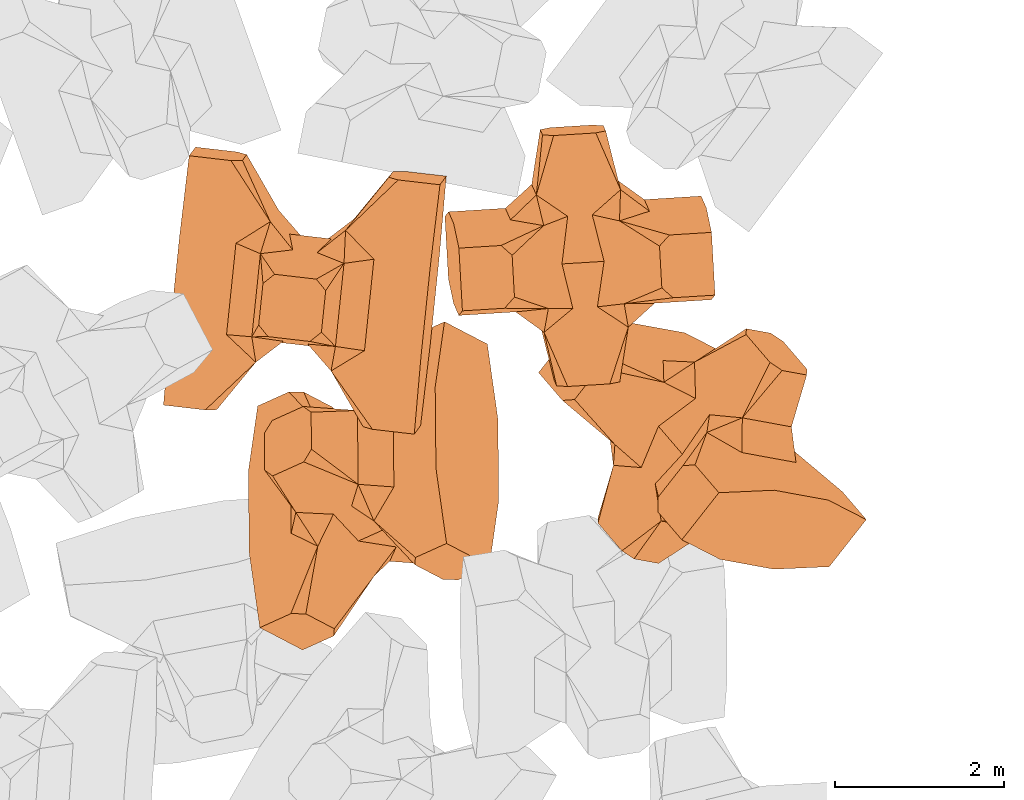
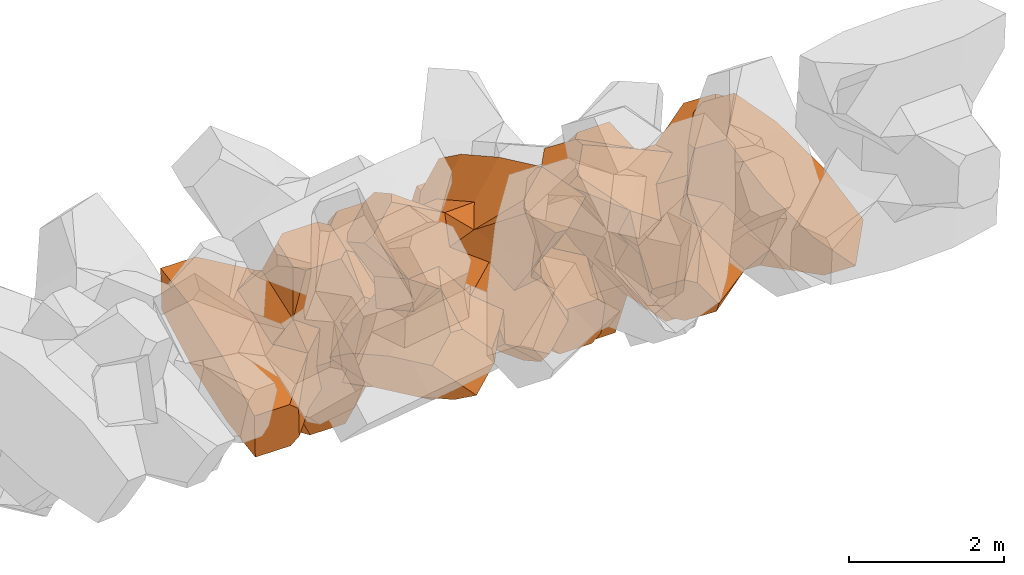
# One storey, part 16 of 17: 4 civil elements.
"""IFC4 building model written with IfcOpenShell, lengths in metres."""

from ifc_helpers import new_model, entity, si_unit, converted_unit, frame, origin_with_axes, origin_2d_with_axis, place, context, subcontext, project, spatial, polygons, element, save


model = new_model("IFC4")

# Units and contexts
model_context = context("Model", 3, precision=1e-05, world=origin_with_axes())
plan_context = context("Plan", 2, precision=1e-05, world=origin_2d_with_axis())
body_context = subcontext(model_context, "Body", "Model", "MODEL_VIEW")
ifc_project = project(units=[si_unit("VOLUMEUNIT", "CUBIC_METRE"), si_unit("LENGTHUNIT", "METRE"), converted_unit("PLANEANGLEUNIT", "degree", entity("IfcReal", 0.0174532925199433), si_unit("PLANEANGLEUNIT", "RADIAN"), dimensions=[0, 0, 0, 0, 0, 0, 0]), si_unit("AREAUNIT", "SQUARE_METRE")], contexts=[model_context, plan_context])

# Site, building, storey
site_placement = place(None, origin_with_axes())
site = spatial("IfcSite", under=ifc_project, at=site_placement)
building_placement = place(site_placement, origin_with_axes())
building = spatial("IfcBuilding", under=site, at=building_placement, Name="Building")
storey_placement = place(building_placement, origin_with_axes())
storey = spatial("IfcBuildingStorey", under=building, at=storey_placement, Name="Storey")

# Civil elements
civil_element_1_placement = place(storey_placement, frame((17.6803112030029, 17.7688827514648, 3.55769681930542), z_axis=(0.100111402480359, 0.136182114358353, -0.985612570345115), x_axis=(0.10141891959531, 0.984032866758023, 0.146265238139852)))
element("IfcCivilElement", 1, at=civil_element_1_placement, inside=storey, ObjectType="IfcCivilElementType", context=body_context, shape_type="Tessellation", body=[
    polygons([(0.500000178813934, 0.500002086162567, 0.821431398391724), (0.374999850988388, 0.250000953674316, 1.50000500679016), (0.550000071525574, 0.145681202411652, 0.550001919269562), (0.374999850988388, -0.250001013278961, 1.50000500679016), (0.651315867900848, -0.250001013278961, 1.45971029041903e-07), (0.651315867900848, 0.250000953674316, 1.45971029041903e-07), (0.550000071525574, -0.145681276917458, 0.550001919269562), (0.500000178813934, -0.500002086162567, 0.821431398391724), (-0.250000029802322, 0.375001281499863, 1.50000500679016), (0.249999985098839, 0.375001281499863, 1.50000500679016), (-0.500000059604645, 0.500002086162567, 0.821431398391724), (-0.550000071525574, 0.825003266334534, 0.550001919269562), (0.550000071525574, 0.825003266334534, 0.550001919269562), (-0.550000071525574, 1.50000607967377, 0.550001919269562), (0.550000071525574, 1.50000607967377, 0.550001919269562), (-0.250000029802322, -0.375001519918442, 1.50000500679016), (0.249999985098839, -0.375001519918442, 1.50000500679016), (-0.375, -0.250001013278961, 1.50000500679016), (-0.375, 0.250000953674316, 1.50000500679016), (1.50000023841858, 0.875003337860107, -0.25000062584877), (1.50000023841858, 0.875003337860107, 0.250000923871994), (0.845557630062103, 0.450001686811447, -0.495556741952896), (0.845557630062103, 0.450001686811447, 0.495556741952896), (1.50000023841858, 1.50000607967377, -0.375001043081284), (1.50000023841858, 1.50000607967377, 0.375001192092896), (1.50000023841858, 1.00000405311584, -0.375001043081284), (1.50000023841858, 1.00000405311584, 0.375001192092896), (-1.50000023841858, 1.50000607967377, -0.375001043081284), (-1.50000023841858, 1.50000607967377, 0.375001192092896), (-0.550000071525574, 1.50000607967377, -0.550001621246338), (0.550000071525574, 1.50000607967377, -0.550001621246338), (0.550000071525574, 0.145681202411652, -0.550001621246338), (-0.500000059604645, -0.500002086162567, 0.821431398391724), (-0.550000071525574, -0.145681276917458, 0.550001919269562), (-0.651315867900848, 0.250000953674316, 1.45971029041903e-07), (-0.651315867900848, -0.250001013278961, 1.45971029041903e-07), (-0.550000071525574, 0.145681202411652, 0.550001919269562), (-1.50000023841858, 0.875003337860107, 0.250000923871994), (-1.50000023841858, 0.875003337860107, -0.25000062584877), (-0.845557451248169, 0.450001686811447, 0.495556741952896), (-0.845557451248169, 0.450001686811447, -0.495556741952896), (-1.50000023841858, 1.00000405311584, 0.375001192092896), (-1.50000023841858, 1.00000405311584, -0.375001043081284), (-0.550000071525574, 0.145681202411652, -0.550001621246338), (0.550000071525574, -0.825003445148468, 0.550001919269562), (-0.550000071525574, -0.825003445148468, 0.550001919269562), (0.550000071525574, -1.50000607967377, 0.550001919269562), (-0.550000071525574, -1.50000607967377, 0.550001919269562), (1.50000023841858, -0.875003576278687, 0.250000923871994), (1.50000023841858, -0.875003576278687, -0.25000062584877), (0.845557630062103, -0.450001925230026, 0.495556741952896), (0.845557630062103, -0.450001925230026, -0.495556741952896), (1.50000023841858, -1.50000607967377, 0.375001192092896), (1.50000023841858, -1.50000607967377, -0.375001043081284), (1.50000023841858, -1.00000417232513, 0.375001192092896), (1.50000023841858, -1.00000417232513, -0.375001043081284), (0.550000071525574, -1.50000607967377, -0.550001621246338), (-0.550000071525574, -1.50000607967377, -0.550001621246338), (-1.50000023841858, -1.50000607967377, -0.375001043081284), (-1.50000023841858, -1.50000607967377, 0.375001192092896), (0.550000071525574, -0.145681276917458, -0.550001621246338), (-1.50000023841858, -0.875003576278687, -0.25000062584877), (-1.50000023841858, -0.875003576278687, 0.250000923871994), (-0.845557451248169, -0.450001925230026, -0.495556741952896), (-0.845557451248169, -0.450001925230026, 0.495556741952896), (-1.50000023841858, -1.00000417232513, -0.375001043081284), (-1.50000023841858, -1.00000417232513, 0.375001192092896), (-0.550000071525574, -0.145681276917458, -0.550001621246338), (0.500000178813934, -0.500002086162567, -0.821431159973145), (0.374999850988388, -0.250001013278961, -1.50000476837158), (0.374999850988388, 0.250000953674316, -1.50000476837158), (0.500000178813934, 0.500002086162567, -0.821431159973145), (0.249999985098839, 0.375001281499863, -1.50000476837158), (-0.250000029802322, 0.375001281499863, -1.50000476837158), (-0.500000059604645, 0.500002086162567, -0.821431159973145), (0.550000071525574, 0.825003266334534, -0.550001621246338), (-0.550000071525574, 0.825003266334534, -0.550001621246338), (0.249999985098839, -0.375001519918442, -1.50000476837158), (-0.250000029802322, -0.375001519918442, -1.50000476837158), (-0.375, -0.250001013278961, -1.50000476837158), (-0.375, 0.250000953674316, -1.50000476837158), (-0.500000059604645, -0.500002086162567, -0.821431159973145), (-0.550000071525574, -0.825003445148468, -0.550001621246338), (0.550000071525574, -0.825003445148468, -0.550001621246338)], [[[1, 2, 3]], [[3, 2, 4]], [[5, 6, 7]], [[7, 6, 3]], [[7, 3, 8]], [[8, 3, 4]], [[9, 10, 11]], [[11, 10, 1]], [[12, 13, 14]], [[14, 13, 15]], [[16, 17, 18]], [[18, 17, 4]], [[18, 4, 19]], [[19, 4, 2]], [[19, 2, 9]], [[9, 2, 10]], [[20, 21, 22]], [[22, 21, 23]], [[24, 25, 26]], [[26, 25, 27]], [[26, 27, 20]], [[20, 27, 21]], [[23, 27, 13]], [[13, 27, 25]], [[13, 25, 15]], [[28, 29, 30]], [[30, 29, 14]], [[30, 14, 31]], [[31, 14, 15]], [[31, 15, 24]], [[24, 15, 25]], [[21, 27, 23]], [[2, 1, 10]], [[13, 12, 1]], [[1, 12, 11]], [[13, 1, 23]], [[32, 22, 6]], [[6, 22, 23]], [[6, 23, 3]], [[3, 23, 1]], [[33, 18, 34]], [[34, 18, 19]], [[35, 36, 37]], [[37, 36, 34]], [[37, 34, 11]], [[11, 34, 19]], [[38, 39, 40]], [[40, 39, 41]], [[29, 28, 42]], [[42, 28, 43]], [[42, 43, 38]], [[38, 43, 39]], [[14, 29, 12]], [[12, 29, 42]], [[12, 42, 40]], [[40, 42, 38]], [[9, 11, 19]], [[40, 11, 12]], [[37, 40, 35]], [[35, 40, 41]], [[35, 41, 44]], [[11, 40, 37]], [[17, 16, 8]], [[8, 16, 33]], [[45, 46, 47]], [[47, 46, 48]], [[49, 50, 51]], [[51, 50, 52]], [[53, 54, 55]], [[55, 54, 56]], [[55, 56, 49]], [[49, 56, 50]], [[47, 53, 45]], [[45, 53, 55]], [[45, 55, 51]], [[54, 53, 57]], [[57, 53, 47]], [[57, 47, 58]], [[58, 47, 48]], [[58, 48, 59]], [[59, 48, 60]], [[51, 55, 49]], [[17, 8, 4]], [[46, 45, 33]], [[33, 45, 8]], [[51, 8, 45]], [[7, 51, 5]], [[5, 51, 52]], [[5, 52, 61]], [[8, 51, 7]], [[62, 63, 64]], [[64, 63, 65]], [[59, 60, 66]], [[66, 60, 67]], [[66, 67, 62]], [[62, 67, 63]], [[65, 67, 46]], [[46, 67, 60]], [[46, 60, 48]], [[63, 67, 65]], [[18, 33, 16]], [[46, 33, 65]], [[68, 64, 36]], [[36, 64, 65]], [[36, 65, 34]], [[34, 65, 33]], [[69, 70, 61]], [[61, 70, 71]], [[6, 5, 32]], [[32, 5, 61]], [[32, 61, 72]], [[72, 61, 71]], [[73, 74, 72]], [[72, 74, 75]], [[76, 77, 31]], [[31, 77, 30]], [[78, 79, 70]], [[70, 79, 80]], [[70, 80, 71]], [[71, 80, 81]], [[71, 81, 73]], [[73, 81, 74]], [[31, 24, 76]], [[76, 24, 26]], [[76, 26, 22]], [[22, 26, 20]], [[73, 72, 71]], [[77, 76, 75]], [[75, 76, 72]], [[22, 72, 76]], [[72, 22, 32]], [[75, 81, 44]], [[44, 81, 80]], [[36, 35, 68]], [[68, 35, 44]], [[68, 44, 82]], [[82, 44, 80]], [[41, 43, 77]], [[77, 43, 28]], [[77, 28, 30]], [[39, 43, 41]], [[81, 75, 74]], [[77, 75, 41]], [[44, 41, 75]], [[79, 78, 82]], [[82, 78, 69]], [[83, 84, 58]], [[58, 84, 57]], [[52, 56, 84]], [[84, 56, 54]], [[84, 54, 57]], [[50, 56, 52]], [[70, 69, 78]], [[84, 83, 69]], [[69, 83, 82]], [[84, 69, 52]], [[61, 52, 69]], [[58, 59, 83]], [[83, 59, 66]], [[83, 66, 64]], [[64, 66, 62]], [[79, 82, 80]], [[64, 82, 83]], [[82, 64, 68]]], closed=True),
])
civil_element_2_placement = place(storey_placement, frame((20.9370365142822, 18.1817531585693, 3.25932431221008), z_axis=(0.0555967069764705, -0.990176524720759, -0.12829441166821), x_axis=(-0.0552358599215612, 0.125246184158641, -0.990586893277125)))
element("IfcCivilElement", 2, at=civil_element_2_placement, inside=storey, ObjectType="IfcCivilElementType", context=body_context, shape_type="Tessellation", body=[
    polygons([(0.500000178813934, 0.500000894069672, 0.821429073810577), (0.374999850988388, 0.250000357627869, 1.50000071525574), (0.550000071525574, 0.145680874586105, 0.550000369548798), (0.374999850988388, -0.250000447034836, 1.50000071525574), (0.651315867900848, -0.250000447034836, 1.45970616927116e-07), (0.651315867900848, 0.250000357627869, 1.45970616927116e-07), (0.550000071525574, -0.14568093419075, 0.550000369548798), (0.500000178813934, -0.500000894069672, 0.821429073810577), (-0.250000029802322, 0.375000417232513, 1.50000071525574), (0.249999985098839, 0.375000417232513, 1.50000071525574), (-0.500000059604645, 0.500000894069672, 0.821429073810577), (-0.550000071525574, 0.825001358985901, 0.550000369548798), (0.550000071525574, 0.825001358985901, 0.550000369548798), (-0.550000071525574, 1.50000250339508, 0.550000369548798), (0.550000071525574, 1.50000250339508, 0.550000369548798), (-0.250000029802322, -0.37500062584877, 1.50000071525574), (0.249999985098839, -0.37500062584877, 1.50000071525574), (-0.375, -0.250000447034836, 1.50000071525574), (-0.375, 0.250000357627869, 1.50000071525574), (1.50000023841858, 0.875001311302185, -0.249999940395355), (1.50000023841858, 0.875001311302185, 0.250000238418579), (0.845557630062103, 0.450000643730164, -0.495555341243744), (0.845557630062103, 0.450000643730164, 0.495555341243744), (1.50000023841858, 1.50000250339508, -0.374999970197678), (1.50000023841858, 1.50000250339508, 0.37500011920929), (1.50000023841858, 1.00000166893005, -0.374999970197678), (1.50000023841858, 1.00000166893005, 0.37500011920929), (-1.50000023841858, 1.50000250339508, -0.374999970197678), (-1.50000023841858, 1.50000250339508, 0.37500011920929), (-0.550000071525574, 1.50000250339508, -0.550000071525574), (0.550000071525574, 1.50000250339508, -0.550000071525574), (0.550000071525574, 0.145680874586105, -0.550000071525574), (-0.500000059604645, -0.500000894069672, 0.821429073810577), (-0.550000071525574, -0.14568093419075, 0.550000369548798), (-0.651315867900848, 0.250000357627869, 1.45970616927116e-07), (-0.651315867900848, -0.250000447034836, 1.45970616927116e-07), (-0.550000071525574, 0.145680874586105, 0.550000369548798), (-1.50000023841858, 0.875001311302185, 0.250000238418579), (-1.50000023841858, 0.875001311302185, -0.249999940395355), (-0.845557451248169, 0.450000643730164, 0.495555341243744), (-0.845557451248169, 0.450000643730164, -0.495555341243744), (-1.50000023841858, 1.00000166893005, 0.37500011920929), (-1.50000023841858, 1.00000166893005, -0.374999970197678), (-0.550000071525574, 0.145680874586105, -0.550000071525574), (0.550000071525574, -0.82500147819519, 0.550000369548798), (-0.550000071525574, -0.82500147819519, 0.550000369548798), (0.550000071525574, -1.50000250339508, 0.550000369548798), (-0.550000071525574, -1.50000250339508, 0.550000369548798), (1.50000023841858, -0.875001549720764, 0.250000238418579), (1.50000023841858, -0.875001549720764, -0.249999940395355), (0.845557630062103, -0.450000882148743, 0.495555341243744), (0.845557630062103, -0.450000882148743, -0.495555341243744), (1.50000023841858, -1.50000250339508, 0.37500011920929), (1.50000023841858, -1.50000250339508, -0.374999970197678), (1.50000023841858, -1.00000178813934, 0.37500011920929), (1.50000023841858, -1.00000178813934, -0.374999970197678), (0.550000071525574, -1.50000250339508, -0.550000071525574), (-0.550000071525574, -1.50000250339508, -0.550000071525574), (-1.50000023841858, -1.50000250339508, -0.374999970197678), (-1.50000023841858, -1.50000250339508, 0.37500011920929), (0.550000071525574, -0.14568093419075, -0.550000071525574), (-1.50000023841858, -0.875001549720764, -0.249999940395355), (-1.50000023841858, -0.875001549720764, 0.250000238418579), (-0.845557451248169, -0.450000882148743, -0.495555341243744), (-0.845557451248169, -0.450000882148743, 0.495555341243744), (-1.50000023841858, -1.00000178813934, -0.374999970197678), (-1.50000023841858, -1.00000178813934, 0.37500011920929), (-0.550000071525574, -0.14568093419075, -0.550000071525574), (0.500000178813934, -0.500000894069672, -0.821428835391998), (0.374999850988388, -0.250000447034836, -1.50000047683716), (0.374999850988388, 0.250000357627869, -1.50000047683716), (0.500000178813934, 0.500000894069672, -0.821428835391998), (0.249999985098839, 0.375000417232513, -1.50000047683716), (-0.250000029802322, 0.375000417232513, -1.50000047683716), (-0.500000059604645, 0.500000894069672, -0.821428835391998), (0.550000071525574, 0.825001358985901, -0.550000071525574), (-0.550000071525574, 0.825001358985901, -0.550000071525574), (0.249999985098839, -0.37500062584877, -1.50000047683716), (-0.250000029802322, -0.37500062584877, -1.50000047683716), (-0.375, -0.250000447034836, -1.50000047683716), (-0.375, 0.250000357627869, -1.50000047683716), (-0.500000059604645, -0.500000894069672, -0.821428835391998), (-0.550000071525574, -0.82500147819519, -0.550000071525574), (0.550000071525574, -0.82500147819519, -0.550000071525574)], [[[1, 2, 3]], [[3, 2, 4]], [[5, 6, 7]], [[7, 6, 3]], [[7, 3, 8]], [[8, 3, 4]], [[9, 10, 11]], [[11, 10, 1]], [[12, 13, 14]], [[14, 13, 15]], [[16, 17, 18]], [[18, 17, 4]], [[18, 4, 19]], [[19, 4, 2]], [[19, 2, 9]], [[9, 2, 10]], [[20, 21, 22]], [[22, 21, 23]], [[24, 25, 26]], [[26, 25, 27]], [[26, 27, 20]], [[20, 27, 21]], [[23, 27, 13]], [[13, 27, 25]], [[13, 25, 15]], [[28, 29, 30]], [[30, 29, 14]], [[30, 14, 31]], [[31, 14, 15]], [[31, 15, 24]], [[24, 15, 25]], [[21, 27, 23]], [[2, 1, 10]], [[13, 12, 1]], [[1, 12, 11]], [[13, 1, 23]], [[32, 22, 6]], [[6, 22, 23]], [[6, 23, 3]], [[3, 23, 1]], [[33, 18, 34]], [[34, 18, 19]], [[35, 36, 37]], [[37, 36, 34]], [[37, 34, 11]], [[11, 34, 19]], [[38, 39, 40]], [[40, 39, 41]], [[29, 28, 42]], [[42, 28, 43]], [[42, 43, 38]], [[38, 43, 39]], [[14, 29, 12]], [[12, 29, 42]], [[12, 42, 40]], [[40, 42, 38]], [[9, 11, 19]], [[40, 11, 12]], [[37, 40, 35]], [[35, 40, 41]], [[35, 41, 44]], [[11, 40, 37]], [[17, 16, 8]], [[8, 16, 33]], [[45, 46, 47]], [[47, 46, 48]], [[49, 50, 51]], [[51, 50, 52]], [[53, 54, 55]], [[55, 54, 56]], [[55, 56, 49]], [[49, 56, 50]], [[47, 53, 45]], [[45, 53, 55]], [[45, 55, 51]], [[54, 53, 57]], [[57, 53, 47]], [[57, 47, 58]], [[58, 47, 48]], [[58, 48, 59]], [[59, 48, 60]], [[51, 55, 49]], [[17, 8, 4]], [[46, 45, 33]], [[33, 45, 8]], [[51, 8, 45]], [[7, 51, 5]], [[5, 51, 52]], [[5, 52, 61]], [[8, 51, 7]], [[62, 63, 64]], [[64, 63, 65]], [[59, 60, 66]], [[66, 60, 67]], [[66, 67, 62]], [[62, 67, 63]], [[65, 67, 46]], [[46, 67, 60]], [[46, 60, 48]], [[63, 67, 65]], [[18, 33, 16]], [[46, 33, 65]], [[68, 64, 36]], [[36, 64, 65]], [[36, 65, 34]], [[34, 65, 33]], [[69, 70, 61]], [[61, 70, 71]], [[6, 5, 32]], [[32, 5, 61]], [[32, 61, 72]], [[72, 61, 71]], [[73, 74, 72]], [[72, 74, 75]], [[76, 77, 31]], [[31, 77, 30]], [[78, 79, 70]], [[70, 79, 80]], [[70, 80, 71]], [[71, 80, 81]], [[71, 81, 73]], [[73, 81, 74]], [[31, 24, 76]], [[76, 24, 26]], [[76, 26, 22]], [[22, 26, 20]], [[73, 72, 71]], [[77, 76, 75]], [[75, 76, 72]], [[22, 72, 76]], [[72, 22, 32]], [[75, 81, 44]], [[44, 81, 80]], [[36, 35, 68]], [[68, 35, 44]], [[68, 44, 82]], [[82, 44, 80]], [[41, 43, 77]], [[77, 43, 28]], [[77, 28, 30]], [[39, 43, 41]], [[81, 75, 74]], [[77, 75, 41]], [[44, 41, 75]], [[79, 78, 82]], [[82, 78, 69]], [[83, 84, 58]], [[58, 84, 57]], [[52, 56, 84]], [[84, 56, 54]], [[84, 54, 57]], [[50, 56, 52]], [[70, 69, 78]], [[84, 83, 69]], [[69, 83, 82]], [[84, 69, 52]], [[61, 52, 69]], [[58, 59, 83]], [[83, 59, 66]], [[83, 66, 64]], [[64, 66, 62]], [[79, 82, 80]], [[64, 82, 83]], [[82, 64, 68]]], closed=True),
])
civil_element_3_placement = place(storey_placement, frame((18.4931964874268, 15.4576587677002, 5.48803520202637), z_axis=(0.67561710909833, -0.352321272494049, -0.647619674532661), x_axis=(-0.00803283054092769, 0.874852967198369, -0.484321958430247)))
element("IfcCivilElement", 3, at=civil_element_3_placement, inside=storey, ObjectType="IfcCivilElementType", context=body_context, shape_type="Tessellation", body=[
    polygons([(0.50000011920929, 0.500000059604645, 0.821428716182709), (0.374999821186066, 0.249999940395355, 1.50000023841858), (0.550000011920929, 0.145680621266365, 0.550000131130219), (0.374999821186066, -0.250000029802322, 1.50000023841858), (0.651315808296204, -0.250000029802322, 1.45970560083697e-07), (0.651315808296204, 0.249999940395355, 1.45970560083697e-07), (0.550000011920929, -0.145680695772171, 0.550000131130219), (0.50000011920929, -0.500000059604645, 0.821428716182709), (-0.25, 0.374999791383743, 1.50000023841858), (0.249999970197678, 0.374999791383743, 1.50000023841858), (-0.500000059604645, 0.500000059604645, 0.821428716182709), (-0.550000011920929, 0.824999988079071, 0.550000131130219), (0.550000011920929, 0.824999988079071, 0.550000131130219), (-0.550000011920929, 1.5, 0.550000131130219), (0.550000011920929, 1.5, 0.550000131130219), (-0.25, -0.375, 1.50000023841858), (0.249999970197678, -0.375, 1.50000023841858), (-0.374999970197678, -0.250000029802322, 1.50000023841858), (-0.374999970197678, 0.249999940395355, 1.50000023841858), (1.5, 0.87499988079071, -0.249999836087227), (1.5, 0.87499988079071, 0.25000011920929), (0.845557510852814, 0.449999898672104, -0.49555516242981), (0.845557510852814, 0.449999898672104, 0.49555516242981), (1.5, 1.5, -0.374999821186066), (1.5, 1.5, 0.374999970197678), (1.5, 1.0, -0.374999821186066), (1.5, 1.0, 0.374999970197678), (-1.5, 1.5, -0.374999821186066), (-1.5, 1.5, 0.374999970197678), (-0.550000011920929, 1.5, -0.549999833106995), (0.550000011920929, 1.5, -0.549999833106995), (0.550000011920929, 0.145680621266365, -0.549999833106995), (-0.500000059604645, -0.500000059604645, 0.821428716182709), (-0.550000011920929, -0.145680695772171, 0.550000131130219), (-0.651315808296204, 0.249999940395355, 1.45970560083697e-07), (-0.651315808296204, -0.250000029802322, 1.45970560083697e-07), (-0.550000011920929, 0.145680621266365, 0.550000131130219), (-1.5, 0.87499988079071, 0.25000011920929), (-1.5, 0.87499988079071, -0.249999836087227), (-0.845557391643524, 0.449999898672104, 0.49555516242981), (-0.845557391643524, 0.449999898672104, -0.49555516242981), (-1.5, 1.0, 0.374999970197678), (-1.5, 1.0, -0.374999821186066), (-0.550000011920929, 0.145680621266365, -0.549999833106995), (0.550000011920929, -0.825000107288361, 0.550000131130219), (-0.550000011920929, -0.825000107288361, 0.550000131130219), (0.550000011920929, -1.5, 0.550000131130219), (-0.550000011920929, -1.5, 0.550000131130219), (1.5, -0.875000059604645, 0.25000011920929), (1.5, -0.875000059604645, -0.249999836087227), (0.845557510852814, -0.450000137090683, 0.49555516242981), (0.845557510852814, -0.450000137090683, -0.49555516242981), (1.5, -1.5, 0.374999970197678), (1.5, -1.5, -0.374999821186066), (1.5, -1.00000011920929, 0.374999970197678), (1.5, -1.00000011920929, -0.374999821186066), (0.550000011920929, -1.5, -0.549999833106995), (-0.550000011920929, -1.5, -0.549999833106995), (-1.5, -1.5, -0.374999821186066), (-1.5, -1.5, 0.374999970197678), (0.550000011920929, -0.145680695772171, -0.549999833106995), (-1.5, -0.875000059604645, -0.249999836087227), (-1.5, -0.875000059604645, 0.25000011920929), (-0.845557391643524, -0.450000137090683, -0.49555516242981), (-0.845557391643524, -0.450000137090683, 0.49555516242981), (-1.5, -1.00000011920929, -0.374999821186066), (-1.5, -1.00000011920929, 0.374999970197678), (-0.550000011920929, -0.145680695772171, -0.549999833106995), (0.50000011920929, -0.500000059604645, -0.821428537368774), (0.374999821186066, -0.250000029802322, -1.49999988079071), (0.374999821186066, 0.249999940395355, -1.49999988079071), (0.50000011920929, 0.500000059604645, -0.821428537368774), (0.249999970197678, 0.374999791383743, -1.49999988079071), (-0.25, 0.374999791383743, -1.49999988079071), (-0.500000059604645, 0.500000059604645, -0.821428537368774), (0.550000011920929, 0.824999988079071, -0.549999833106995), (-0.550000011920929, 0.824999988079071, -0.549999833106995), (0.249999970197678, -0.375, -1.49999988079071), (-0.25, -0.375, -1.49999988079071), (-0.374999970197678, -0.250000029802322, -1.49999988079071), (-0.374999970197678, 0.249999940395355, -1.49999988079071), (-0.500000059604645, -0.500000059604645, -0.821428537368774), (-0.550000011920929, -0.825000107288361, -0.549999833106995), (0.550000011920929, -0.825000107288361, -0.549999833106995)], [[[1, 2, 3]], [[3, 2, 4]], [[5, 6, 7]], [[7, 6, 3]], [[7, 3, 8]], [[8, 3, 4]], [[9, 10, 11]], [[11, 10, 1]], [[12, 13, 14]], [[14, 13, 15]], [[16, 17, 18]], [[18, 17, 4]], [[18, 4, 19]], [[19, 4, 2]], [[19, 2, 9]], [[9, 2, 10]], [[20, 21, 22]], [[22, 21, 23]], [[24, 25, 26]], [[26, 25, 27]], [[26, 27, 20]], [[20, 27, 21]], [[23, 27, 13]], [[13, 27, 25]], [[13, 25, 15]], [[28, 29, 30]], [[30, 29, 14]], [[30, 14, 31]], [[31, 14, 15]], [[31, 15, 24]], [[24, 15, 25]], [[21, 27, 23]], [[2, 1, 10]], [[13, 12, 1]], [[1, 12, 11]], [[13, 1, 23]], [[32, 22, 6]], [[6, 22, 23]], [[6, 23, 3]], [[3, 23, 1]], [[33, 18, 34]], [[34, 18, 19]], [[35, 36, 37]], [[37, 36, 34]], [[37, 34, 11]], [[11, 34, 19]], [[38, 39, 40]], [[40, 39, 41]], [[29, 28, 42]], [[42, 28, 43]], [[42, 43, 38]], [[38, 43, 39]], [[14, 29, 12]], [[12, 29, 42]], [[12, 42, 40]], [[40, 42, 38]], [[9, 11, 19]], [[40, 11, 12]], [[37, 40, 35]], [[35, 40, 41]], [[35, 41, 44]], [[11, 40, 37]], [[17, 16, 8]], [[8, 16, 33]], [[45, 46, 47]], [[47, 46, 48]], [[49, 50, 51]], [[51, 50, 52]], [[53, 54, 55]], [[55, 54, 56]], [[55, 56, 49]], [[49, 56, 50]], [[47, 53, 45]], [[45, 53, 55]], [[45, 55, 51]], [[54, 53, 57]], [[57, 53, 47]], [[57, 47, 58]], [[58, 47, 48]], [[58, 48, 59]], [[59, 48, 60]], [[51, 55, 49]], [[17, 8, 4]], [[46, 45, 33]], [[33, 45, 8]], [[51, 8, 45]], [[7, 51, 5]], [[5, 51, 52]], [[5, 52, 61]], [[8, 51, 7]], [[62, 63, 64]], [[64, 63, 65]], [[59, 60, 66]], [[66, 60, 67]], [[66, 67, 62]], [[62, 67, 63]], [[65, 67, 46]], [[46, 67, 60]], [[46, 60, 48]], [[63, 67, 65]], [[18, 33, 16]], [[46, 33, 65]], [[68, 64, 36]], [[36, 64, 65]], [[36, 65, 34]], [[34, 65, 33]], [[69, 70, 61]], [[61, 70, 71]], [[6, 5, 32]], [[32, 5, 61]], [[32, 61, 72]], [[72, 61, 71]], [[73, 74, 72]], [[72, 74, 75]], [[76, 77, 31]], [[31, 77, 30]], [[78, 79, 70]], [[70, 79, 80]], [[70, 80, 71]], [[71, 80, 81]], [[71, 81, 73]], [[73, 81, 74]], [[31, 24, 76]], [[76, 24, 26]], [[76, 26, 22]], [[22, 26, 20]], [[73, 72, 71]], [[77, 76, 75]], [[75, 76, 72]], [[22, 72, 76]], [[72, 22, 32]], [[75, 81, 44]], [[44, 81, 80]], [[36, 35, 68]], [[68, 35, 44]], [[68, 44, 82]], [[82, 44, 80]], [[41, 43, 77]], [[77, 43, 28]], [[77, 28, 30]], [[39, 43, 41]], [[81, 75, 74]], [[77, 75, 41]], [[44, 41, 75]], [[79, 78, 82]], [[82, 78, 69]], [[83, 84, 58]], [[58, 84, 57]], [[52, 56, 84]], [[84, 56, 54]], [[84, 54, 57]], [[50, 56, 52]], [[70, 69, 78]], [[84, 83, 69]], [[69, 83, 82]], [[84, 69, 52]], [[61, 52, 69]], [[58, 59, 83]], [[83, 59, 66]], [[83, 66, 64]], [[64, 66, 62]], [[79, 82, 80]], [[64, 82, 83]], [[82, 64, 68]]], closed=True),
])
civil_element_4_placement = place(storey_placement, frame((22.3863182067871, 15.9285640716553, 4.94035959243774), z_axis=(-0.584795841228034, -0.743723164997624, -0.32386675952977), x_axis=(0.581658006170046, -0.10616952189179, -0.806475043928549)))
element("IfcCivilElement", 4, at=civil_element_4_placement, inside=storey, ObjectType="IfcCivilElementType", context=body_context, shape_type="Tessellation", body=[
    polygons([(0.50000011920929, 0.500000059604645, 0.821428716182709), (0.374999821186066, 0.249999940395355, 1.50000023841858), (0.550000011920929, 0.145680621266365, 0.550000131130219), (0.374999821186066, -0.250000029802322, 1.50000023841858), (0.651315808296204, -0.250000029802322, 1.45970560083697e-07), (0.651315808296204, 0.249999940395355, 1.45970560083697e-07), (0.550000011920929, -0.145680695772171, 0.550000131130219), (0.50000011920929, -0.500000059604645, 0.821428716182709), (-0.25, 0.374999791383743, 1.50000023841858), (0.249999970197678, 0.374999791383743, 1.50000023841858), (-0.500000059604645, 0.500000059604645, 0.821428716182709), (-0.550000011920929, 0.824999988079071, 0.550000131130219), (0.550000011920929, 0.824999988079071, 0.550000131130219), (-0.550000011920929, 1.5, 0.550000131130219), (0.550000011920929, 1.5, 0.550000131130219), (-0.25, -0.375, 1.50000023841858), (0.249999970197678, -0.375, 1.50000023841858), (-0.374999970197678, -0.250000029802322, 1.50000023841858), (-0.374999970197678, 0.249999940395355, 1.50000023841858), (1.5, 0.87499988079071, -0.249999836087227), (1.5, 0.87499988079071, 0.25000011920929), (0.845557510852814, 0.449999898672104, -0.49555516242981), (0.845557510852814, 0.449999898672104, 0.49555516242981), (1.5, 1.5, -0.374999821186066), (1.5, 1.5, 0.374999970197678), (1.5, 1.0, -0.374999821186066), (1.5, 1.0, 0.374999970197678), (-1.5, 1.5, -0.374999821186066), (-1.5, 1.5, 0.374999970197678), (-0.550000011920929, 1.5, -0.549999833106995), (0.550000011920929, 1.5, -0.549999833106995), (0.550000011920929, 0.145680621266365, -0.549999833106995), (-0.500000059604645, -0.500000059604645, 0.821428716182709), (-0.550000011920929, -0.145680695772171, 0.550000131130219), (-0.651315808296204, 0.249999940395355, 1.45970560083697e-07), (-0.651315808296204, -0.250000029802322, 1.45970560083697e-07), (-0.550000011920929, 0.145680621266365, 0.550000131130219), (-1.5, 0.87499988079071, 0.25000011920929), (-1.5, 0.87499988079071, -0.249999836087227), (-0.845557391643524, 0.449999898672104, 0.49555516242981), (-0.845557391643524, 0.449999898672104, -0.49555516242981), (-1.5, 1.0, 0.374999970197678), (-1.5, 1.0, -0.374999821186066), (-0.550000011920929, 0.145680621266365, -0.549999833106995), (0.550000011920929, -0.825000107288361, 0.550000131130219), (-0.550000011920929, -0.825000107288361, 0.550000131130219), (0.550000011920929, -1.5, 0.550000131130219), (-0.550000011920929, -1.5, 0.550000131130219), (1.5, -0.875000059604645, 0.25000011920929), (1.5, -0.875000059604645, -0.249999836087227), (0.845557510852814, -0.450000137090683, 0.49555516242981), (0.845557510852814, -0.450000137090683, -0.49555516242981), (1.5, -1.5, 0.374999970197678), (1.5, -1.5, -0.374999821186066), (1.5, -1.00000011920929, 0.374999970197678), (1.5, -1.00000011920929, -0.374999821186066), (0.550000011920929, -1.5, -0.549999833106995), (-0.550000011920929, -1.5, -0.549999833106995), (-1.5, -1.5, -0.374999821186066), (-1.5, -1.5, 0.374999970197678), (0.550000011920929, -0.145680695772171, -0.549999833106995), (-1.5, -0.875000059604645, -0.249999836087227), (-1.5, -0.875000059604645, 0.25000011920929), (-0.845557391643524, -0.450000137090683, -0.49555516242981), (-0.845557391643524, -0.450000137090683, 0.49555516242981), (-1.5, -1.00000011920929, -0.374999821186066), (-1.5, -1.00000011920929, 0.374999970197678), (-0.550000011920929, -0.145680695772171, -0.549999833106995), (0.50000011920929, -0.500000059604645, -0.821428537368774), (0.374999821186066, -0.250000029802322, -1.49999988079071), (0.374999821186066, 0.249999940395355, -1.49999988079071), (0.50000011920929, 0.500000059604645, -0.821428537368774), (0.249999970197678, 0.374999791383743, -1.49999988079071), (-0.25, 0.374999791383743, -1.49999988079071), (-0.500000059604645, 0.500000059604645, -0.821428537368774), (0.550000011920929, 0.824999988079071, -0.549999833106995), (-0.550000011920929, 0.824999988079071, -0.549999833106995), (0.249999970197678, -0.375, -1.49999988079071), (-0.25, -0.375, -1.49999988079071), (-0.374999970197678, -0.250000029802322, -1.49999988079071), (-0.374999970197678, 0.249999940395355, -1.49999988079071), (-0.500000059604645, -0.500000059604645, -0.821428537368774), (-0.550000011920929, -0.825000107288361, -0.549999833106995), (0.550000011920929, -0.825000107288361, -0.549999833106995)], [[[1, 2, 3]], [[3, 2, 4]], [[5, 6, 7]], [[7, 6, 3]], [[7, 3, 8]], [[8, 3, 4]], [[9, 10, 11]], [[11, 10, 1]], [[12, 13, 14]], [[14, 13, 15]], [[16, 17, 18]], [[18, 17, 4]], [[18, 4, 19]], [[19, 4, 2]], [[19, 2, 9]], [[9, 2, 10]], [[20, 21, 22]], [[22, 21, 23]], [[24, 25, 26]], [[26, 25, 27]], [[26, 27, 20]], [[20, 27, 21]], [[23, 27, 13]], [[13, 27, 25]], [[13, 25, 15]], [[28, 29, 30]], [[30, 29, 14]], [[30, 14, 31]], [[31, 14, 15]], [[31, 15, 24]], [[24, 15, 25]], [[21, 27, 23]], [[2, 1, 10]], [[13, 12, 1]], [[1, 12, 11]], [[13, 1, 23]], [[32, 22, 6]], [[6, 22, 23]], [[6, 23, 3]], [[3, 23, 1]], [[33, 18, 34]], [[34, 18, 19]], [[35, 36, 37]], [[37, 36, 34]], [[37, 34, 11]], [[11, 34, 19]], [[38, 39, 40]], [[40, 39, 41]], [[29, 28, 42]], [[42, 28, 43]], [[42, 43, 38]], [[38, 43, 39]], [[14, 29, 12]], [[12, 29, 42]], [[12, 42, 40]], [[40, 42, 38]], [[9, 11, 19]], [[40, 11, 12]], [[37, 40, 35]], [[35, 40, 41]], [[35, 41, 44]], [[11, 40, 37]], [[17, 16, 8]], [[8, 16, 33]], [[45, 46, 47]], [[47, 46, 48]], [[49, 50, 51]], [[51, 50, 52]], [[53, 54, 55]], [[55, 54, 56]], [[55, 56, 49]], [[49, 56, 50]], [[47, 53, 45]], [[45, 53, 55]], [[45, 55, 51]], [[54, 53, 57]], [[57, 53, 47]], [[57, 47, 58]], [[58, 47, 48]], [[58, 48, 59]], [[59, 48, 60]], [[51, 55, 49]], [[17, 8, 4]], [[46, 45, 33]], [[33, 45, 8]], [[51, 8, 45]], [[7, 51, 5]], [[5, 51, 52]], [[5, 52, 61]], [[8, 51, 7]], [[62, 63, 64]], [[64, 63, 65]], [[59, 60, 66]], [[66, 60, 67]], [[66, 67, 62]], [[62, 67, 63]], [[65, 67, 46]], [[46, 67, 60]], [[46, 60, 48]], [[63, 67, 65]], [[18, 33, 16]], [[46, 33, 65]], [[68, 64, 36]], [[36, 64, 65]], [[36, 65, 34]], [[34, 65, 33]], [[69, 70, 61]], [[61, 70, 71]], [[6, 5, 32]], [[32, 5, 61]], [[32, 61, 72]], [[72, 61, 71]], [[73, 74, 72]], [[72, 74, 75]], [[76, 77, 31]], [[31, 77, 30]], [[78, 79, 70]], [[70, 79, 80]], [[70, 80, 71]], [[71, 80, 81]], [[71, 81, 73]], [[73, 81, 74]], [[31, 24, 76]], [[76, 24, 26]], [[76, 26, 22]], [[22, 26, 20]], [[73, 72, 71]], [[77, 76, 75]], [[75, 76, 72]], [[22, 72, 76]], [[72, 22, 32]], [[75, 81, 44]], [[44, 81, 80]], [[36, 35, 68]], [[68, 35, 44]], [[68, 44, 82]], [[82, 44, 80]], [[41, 43, 77]], [[77, 43, 28]], [[77, 28, 30]], [[39, 43, 41]], [[81, 75, 74]], [[77, 75, 41]], [[44, 41, 75]], [[79, 78, 82]], [[82, 78, 69]], [[83, 84, 58]], [[58, 84, 57]], [[52, 56, 84]], [[84, 56, 54]], [[84, 54, 57]], [[50, 56, 52]], [[70, 69, 78]], [[84, 83, 69]], [[69, 83, 82]], [[84, 69, 52]], [[61, 52, 69]], [[58, 59, 83]], [[83, 59, 66]], [[83, 66, 64]], [[64, 66, 62]], [[79, 82, 80]], [[64, 82, 83]], [[82, 64, 68]]], closed=True),
])

save(model, "model.ifc")
